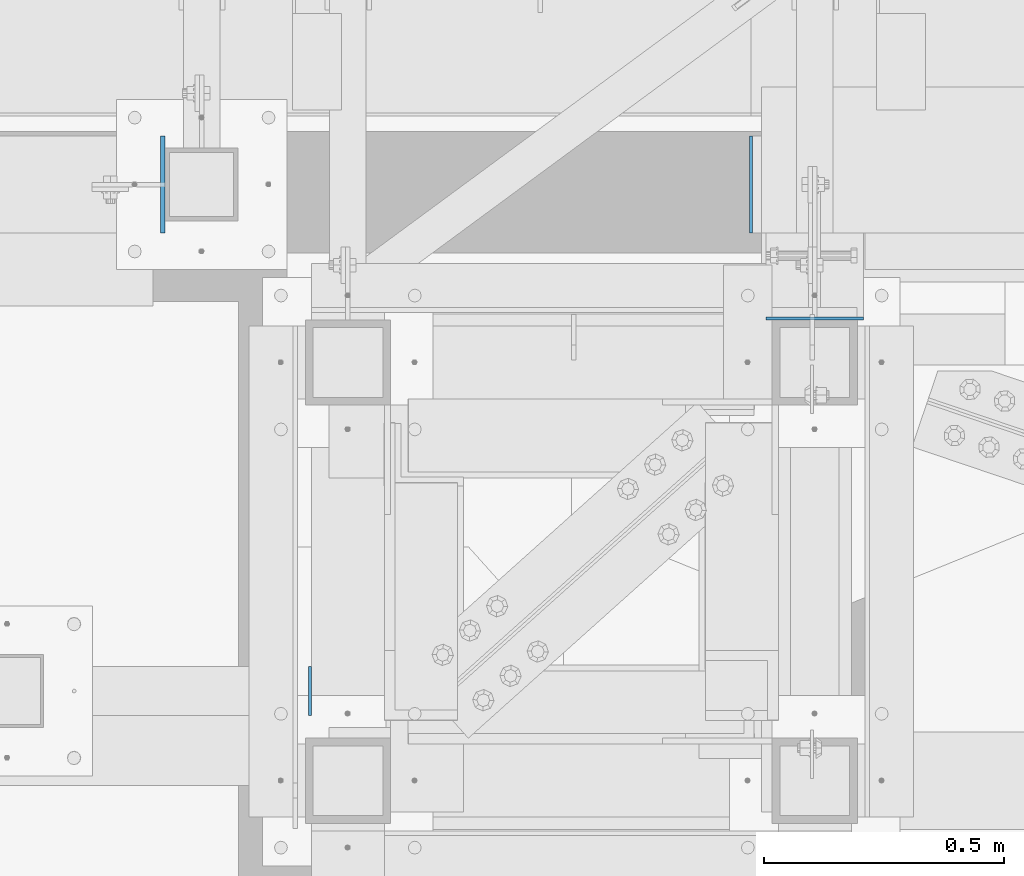
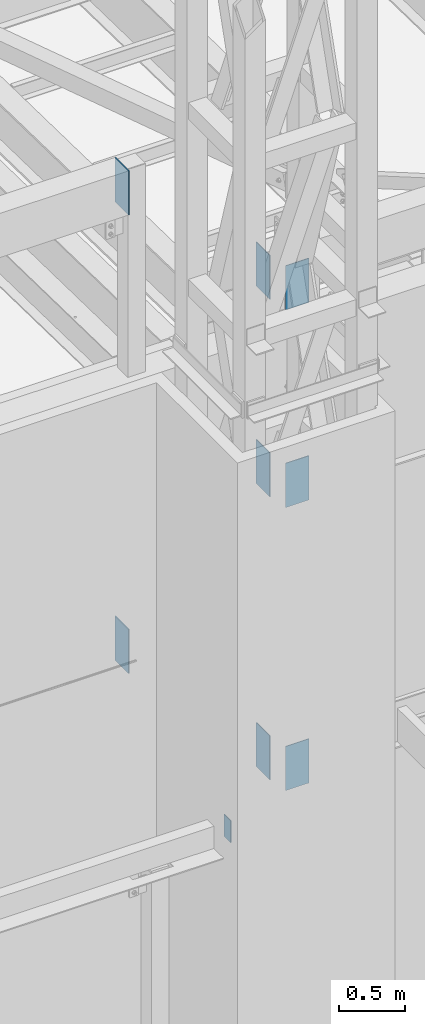
# One storey, part 929 of 1763: 9 columns, 7 elements without a shape of their own.
"""IFC2X3 building model written with IfcOpenShell, lengths in millimetres."""

from ifc_helpers import new_model, si_unit, frame, origin_with_axes, place, context, subcontext, project, spatial, faceted_brep, material, type_object, element, aggregate, save


model = new_model("IFC2X3")

# Units and contexts
model_context = context("Model", 3, precision=1e-05, world=origin_with_axes())
body_context = subcontext(model_context, "Body", "Model", "MODEL_VIEW")
ifc_project = project(units=[si_unit("LENGTHUNIT", "METRE", prefix="MILLI"), si_unit("AREAUNIT", "SQUARE_METRE"), si_unit("VOLUMEUNIT", "CUBIC_METRE"), si_unit("MASSUNIT", "GRAM", prefix="KILO"), si_unit("TIMEUNIT", "SECOND"), si_unit("PLANEANGLEUNIT", "RADIAN"), si_unit("SOLIDANGLEUNIT", "STERADIAN"), si_unit("THERMODYNAMICTEMPERATUREUNIT", "DEGREE_CELSIUS"), si_unit("LUMINOUSINTENSITYUNIT", "LUMEN")], contexts=[model_context])

# Site, building, storey
site_placement = place(None, origin_with_axes())
site = spatial("IfcSite", under=ifc_project, at=site_placement, CompositionType="ELEMENT")
building_placement = place(site_placement, origin_with_axes())
building = spatial("IfcBuilding", under=site, at=building_placement, Name="Undefined", CompositionType="ELEMENT")
storey_placement = place(building_placement, origin_with_axes())
storey = spatial("IfcBuildingStorey", under=building, at=storey_placement, Name="Undefined", CompositionType="ELEMENT", Elevation=0.0)

# Assembly, columns
assembly_1_placement = place(storey_placement, origin_with_axes())
assembly_1 = element("IfcElementAssembly", 1, at=assembly_1_placement, inside=storey, Name="FRAME", AssemblyPlace="NOTDEFINED", PredefinedType="RIGID_FRAME")
ifc_material_1 = material(Name="STEEL/A36")
column_type_1 = type_object("IfcColumnType", PredefinedType="NOTDEFINED")
column_1_placement = place(assembly_1_placement, frame((-63210.5025998724, -14487.5273151468, 12852.4221257957), z_axis=(1.0, 0.0, 0.0), x_axis=(0.0, 0.0, 1.0)))
column_1 = element("IfcColumn", 2, at=column_1_placement, type_object=column_type_1, material=ifc_material_1, Name="PLATE", context=body_context, shape_type="Brep", body=[
    faceted_brep([(0.0, 3.1749999995518, -101.600000000005), (0.0, 3.17499999999927, 101.599998474121), (406.400000000001, 3.1749999999538, 101.599999999984), (406.400000000001, 3.17500000004293, -101.600000000013), (0.0, -3.17499999999927, 101.599998474121), (406.400000000001, -3.17500000004475, 101.600000000006), (0.0, -3.17500000051223, -101.600000000012), (406.400000000001, -3.17499999995562, -101.599999999991)], [[[0, 1, 2, 3]], [[1, 4, 5, 2]], [[4, 6, 7, 5]], [[6, 0, 3, 7]], [[5, 7, 3, 2]], [[6, 4, 1, 0]]]),
])
column_2_placement = place(assembly_1_placement, frame((-63210.5025955482, -14487.5273090425, 11036.3), z_axis=(1.0, 0.0, 0.0), x_axis=(0.0, 0.0, 1.0)))
column_2 = element("IfcColumn", 3, at=column_2_placement, type_object=column_type_1, material=ifc_material_1, Name="PLATE", context=body_context, shape_type="Brep", body=[
    faceted_brep([(0.0, 3.1749999995518, -101.600000000005), (0.0, 3.17499999999927, 101.599998474121), (406.400000000001, 3.1749999999538, 101.599999999984), (406.400000000001, 3.17500000004293, -101.600000000013), (0.0, -3.17499999999927, 101.599998474121), (406.400000000001, -3.17500000004475, 101.600000000006), (0.0, -3.17500000051223, -101.600000000012), (406.400000000001, -3.17499999995562, -101.599999999991)], [[[0, 1, 2, 3]], [[1, 4, 5, 2]], [[4, 6, 7, 5]], [[6, 0, 3, 7]], [[5, 7, 3, 2]], [[6, 4, 1, 0]]]),
])
column_3_placement = place(assembly_1_placement, frame((-63210.5025997217, -14487.5272745336, 8432.8), z_axis=(1.0, 0.0, 0.0), x_axis=(0.0, 0.0, 1.0)))
column_3 = element("IfcColumn", 4, at=column_3_placement, type_object=column_type_1, material=ifc_material_1, Name="PLATE", context=body_context, shape_type="Brep", body=[
    faceted_brep([(0.0, 3.1749999995518, -101.600000000005), (0.0, 3.17499999999927, 101.599998474121), (406.400000000001, 3.1749999999538, 101.599999999984), (406.400000000001, 3.17500000004293, -101.600000000013), (0.0, -3.17499999999927, 101.599998474121), (406.400000000001, -3.17500000004475, 101.600000000006), (0.0, -3.17500000051223, -101.600000000012), (406.400000000001, -3.17499999995562, -101.599999999991)], [[[0, 1, 2, 3]], [[1, 4, 5, 2]], [[4, 6, 7, 5]], [[6, 0, 3, 7]], [[5, 7, 3, 2]], [[6, 4, 1, 0]]]),
])
aggregate(assembly_1, [column_1, column_2, column_3])

# Assembly, column
assembly_2_placement = place(storey_placement, origin_with_axes())
assembly_2 = element("IfcElementAssembly", 5, at=assembly_2_placement, inside=storey, Name="BEAM", AssemblyPlace="NOTDEFINED", PredefinedType="RIGID_FRAME")
ifc_material_2 = material(Name="STEEL/A572-50")
column_4_placement = place(assembly_2_placement, frame((-63343.8525957006, -14208.1276214906, 8432.8), z_axis=(0.0, -1.0, 0.0), x_axis=(0.0, 0.0, 1.0)))
column_4 = element("IfcColumn", 6, at=column_4_placement, type_object=column_type_1, material=ifc_material_2, Name="PLATE", context=body_context, shape_type="Brep", body=[
    faceted_brep([(0.0, 3.1749999995518, -101.600000000005), (0.0, 3.17499999999927, 101.599998474121), (406.400000000001, 3.1749999999538, 101.599999999984), (406.400000000001, 3.17500000004293, -101.600000000013), (0.0, -3.17499999999927, 101.599998474121), (406.400000000001, -3.17500000004475, 101.600000000006), (0.0, -3.17500000051223, -101.600000000012), (406.400000000001, -3.17499999995562, -101.599999999991)], [[[0, 1, 2, 3]], [[1, 4, 5, 2]], [[4, 6, 7, 5]], [[6, 0, 3, 7]], [[5, 7, 3, 2]], [[6, 4, 1, 0]]]),
])
aggregate(assembly_2, [column_4])

assembly_3_placement = place(storey_placement, origin_with_axes())
assembly_3 = element("IfcElementAssembly", 7, at=assembly_3_placement, inside=storey, Name="BEAM", AssemblyPlace="NOTDEFINED", PredefinedType="RIGID_FRAME")
column_5_placement = place(assembly_3_placement, frame((-63343.8525957751, -14208.1276214906, 12852.4221257957), z_axis=(0.0, -1.0, 0.0), x_axis=(0.0, 0.0, 1.0)))
column_5 = element("IfcColumn", 8, at=column_5_placement, type_object=column_type_1, material=ifc_material_1, Name="PLATE", context=body_context, shape_type="Brep", body=[
    faceted_brep([(0.0, 3.1749999995518, -101.600000000005), (0.0, 3.17499999999927, 101.599998474121), (406.400000000001, 3.1749999999538, 101.599999999984), (406.400000000001, 3.17500000004293, -101.600000000013), (0.0, -3.17499999999927, 101.599998474121), (406.400000000001, -3.17500000004475, 101.600000000006), (0.0, -3.17500000051223, -101.600000000012), (406.400000000001, -3.17499999995562, -101.599999999991)], [[[0, 1, 2, 3]], [[1, 4, 5, 2]], [[4, 6, 7, 5]], [[6, 0, 3, 7]], [[5, 7, 3, 2]], [[6, 4, 1, 0]]]),
])
aggregate(assembly_3, [column_5])

assembly_4_placement = place(storey_placement, origin_with_axes())
assembly_4 = element("IfcElementAssembly", 9, at=assembly_4_placement, inside=storey, Name="BEAM", AssemblyPlace="NOTDEFINED", PredefinedType="RIGID_FRAME")
column_6_placement = place(assembly_4_placement, frame((-63343.852591527, -14208.1276214906, 11036.3), z_axis=(0.0, -1.0, 0.0), x_axis=(0.0, 0.0, 1.0)))
column_6 = element("IfcColumn", 10, at=column_6_placement, type_object=column_type_1, material=ifc_material_2, Name="PLATE", context=body_context, shape_type="Brep", body=[
    faceted_brep([(0.0, 3.1749999995518, -101.600000000005), (0.0, 3.17499999999927, 101.599998474121), (406.400000000001, 3.1749999999538, 101.599999999984), (406.400000000001, 3.17500000004293, -101.600000000013), (0.0, -3.17499999999927, 101.599998474121), (406.400000000001, -3.17500000004475, 101.600000000006), (0.0, -3.17500000051223, -101.600000000012), (406.400000000001, -3.17499999995562, -101.599999999991)], [[[0, 1, 2, 3]], [[1, 4, 5, 2]], [[4, 6, 7, 5]], [[6, 0, 3, 7]], [[5, 7, 3, 2]], [[6, 4, 1, 0]]]),
])
aggregate(assembly_4, [column_6])

assembly_5_placement = place(storey_placement, origin_with_axes())
assembly_5 = element("IfcElementAssembly", 11, at=assembly_5_placement, inside=storey, Name="BEAM", AssemblyPlace="NOTDEFINED", PredefinedType="RIGID_FRAME")
column_type_2 = type_object("IfcColumnType", PredefinedType="NOTDEFINED")
column_7_placement = place(assembly_5_placement, frame((-64571.4448740919, -14208.1264769908, 14058.9), z_axis=(0.0, 1.0, 0.0), x_axis=(0.0, 0.0, 1.0)))
column_7 = element("IfcColumn", 12, at=column_7_placement, type_object=column_type_2, material=ifc_material_1, Name="PLATE", context=body_context, shape_type="Brep", body=[
    faceted_brep([(-5.0931703299284e-10, 4.76249999999982, -101.600000000009), (0.0, 4.76250000000243, 101.60001373291), (406.400000000001, 4.76249999999709, 101.6), (406.400000000001, 4.76249999999709, -101.6), (1.45519152283669e-11, -4.76250000000448, 101.60001373291), (406.400000000001, -4.76249999999709, 101.6), (-5.0931703299284e-10, -4.76249999999982, -101.600000000009), (406.400000000001, -4.76249999999709, -101.6)], [[[0, 1, 2, 3]], [[1, 4, 5, 2]], [[4, 6, 7, 5]], [[6, 0, 3, 7]], [[5, 7, 3, 2]], [[6, 4, 1, 0]]]),
])
aggregate(assembly_5, [column_7])

assembly_6_placement = place(storey_placement, origin_with_axes())
assembly_6 = element("IfcElementAssembly", 13, at=assembly_6_placement, inside=storey, Name="BEAM", AssemblyPlace="NOTDEFINED", PredefinedType="RIGID_FRAME")
column_8_placement = place(assembly_6_placement, frame((-64571.4448740919, -14208.1264769908, 9842.5), z_axis=(0.0, 1.0, 0.0), x_axis=(0.0, 0.0, 1.0)))
column_8 = element("IfcColumn", 14, at=column_8_placement, type_object=column_type_2, material=ifc_material_1, Name="PLATE", context=body_context, shape_type="Brep", body=[
    faceted_brep([(-5.0931703299284e-10, 4.76249999999982, -101.600000000009), (0.0, 4.76250000000243, 101.60001373291), (406.400000000001, 4.76249999999709, 101.6), (406.400000000001, 4.76249999999709, -101.6), (1.45519152283669e-11, -4.76250000000448, 101.60001373291), (406.400000000001, -4.76249999999709, 101.6), (-5.0931703299284e-10, -4.76249999999982, -101.600000000009), (406.400000000001, -4.76249999999709, -101.6)], [[[0, 1, 2, 3]], [[1, 4, 5, 2]], [[4, 6, 7, 5]], [[6, 0, 3, 7]], [[5, 7, 3, 2]], [[6, 4, 1, 0]]]),
])
aggregate(assembly_6, [column_8])

assembly_7_placement = place(storey_placement, origin_with_axes())
assembly_7 = element("IfcElementAssembly", 15, at=assembly_7_placement, inside=storey, Name="BEAM", AssemblyPlace="NOTDEFINED", PredefinedType="RIGID_FRAME")
column_type_3 = type_object("IfcColumnType", PredefinedType="NOTDEFINED")
column_9_placement = place(assembly_7_placement, frame((-64264.6027910131, -15265.4000613784, 8788.4), z_axis=(0.0, 1.0, 0.0), x_axis=(0.0, 0.0, 1.0)))
column_9 = element("IfcColumn", 16, at=column_9_placement, type_object=column_type_3, material=ifc_material_1, Name="PLATE", context=body_context, shape_type="Brep", body=[
    faceted_brep([(0.0, 3.17500000000291, -50.7999999999993), (0.0, 3.17500000000291, 50.7999992370605), (203.200000000001, 3.17500000000291, 50.7999999999993), (203.200000000001, 3.17500000000291, -50.7999999999993), (0.0, -3.17500000000291, 50.7999992370605), (203.200000000001, -3.17500000000291, 50.7999999999993), (0.0, -3.17500000000291, -50.7999999999993), (203.200000000001, -3.17500000000291, -50.7999999999993)], [[[0, 1, 2, 3]], [[1, 4, 5, 2]], [[4, 6, 7, 5]], [[6, 0, 3, 7]], [[5, 7, 3, 2]], [[6, 4, 1, 0]]]),
])
aggregate(assembly_7, [column_9])

save(model, "model.ifc")
